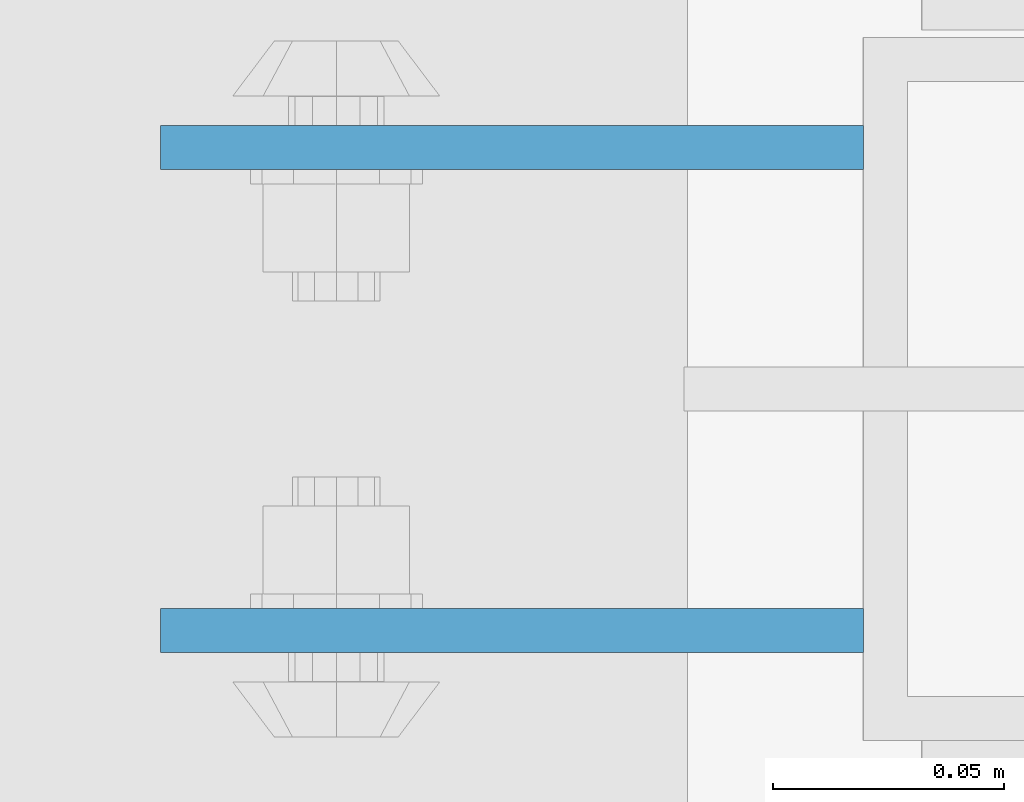
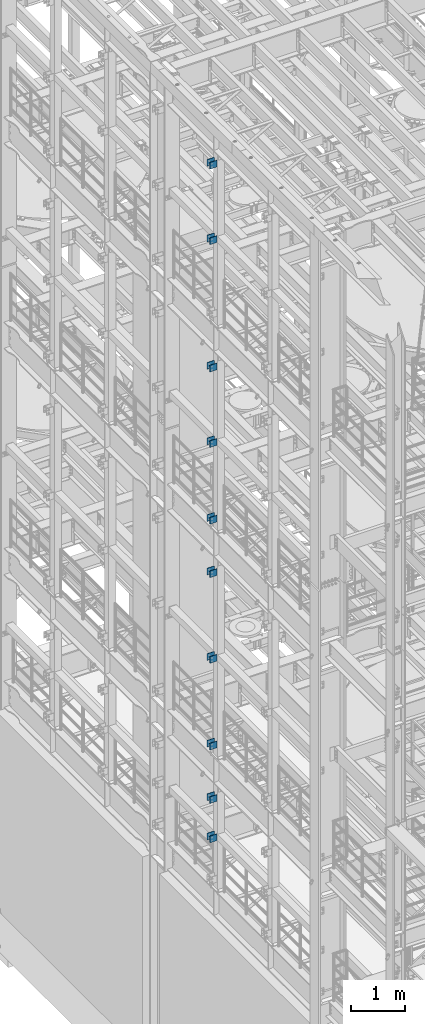
# One storey, part 1232 of 1876: 20 beams, 4 elements without a shape of their own.
"""IFC2X3 building model written with IfcOpenShell, lengths in millimetres."""

from ifc_helpers import new_model, si_unit, frame, origin_with_axes, place, context, subcontext, project, spatial, faceted_brep, material, type_object, element, aggregate, save


model = new_model("IFC2X3")

# Units and contexts
model_context = context("Model", 3, precision=1e-05, world=origin_with_axes())
body_context = subcontext(model_context, "Body", "Model", "MODEL_VIEW")
ifc_project = project(units=[si_unit("LENGTHUNIT", "METRE", prefix="MILLI"), si_unit("AREAUNIT", "SQUARE_METRE"), si_unit("VOLUMEUNIT", "CUBIC_METRE"), si_unit("MASSUNIT", "GRAM", prefix="KILO"), si_unit("TIMEUNIT", "SECOND"), si_unit("PLANEANGLEUNIT", "RADIAN"), si_unit("SOLIDANGLEUNIT", "STERADIAN"), si_unit("THERMODYNAMICTEMPERATUREUNIT", "DEGREE_CELSIUS"), si_unit("LUMINOUSINTENSITYUNIT", "LUMEN")], contexts=[model_context])

# Site, building, storey
site_placement = place(None, origin_with_axes())
site = spatial("IfcSite", under=ifc_project, at=site_placement, CompositionType="ELEMENT")
building_placement = place(site_placement, origin_with_axes())
building = spatial("IfcBuilding", under=site, at=building_placement, Name="Undefined", CompositionType="ELEMENT")
storey_placement = place(building_placement, origin_with_axes())
storey = spatial("IfcBuildingStorey", under=building, at=storey_placement, Name="Undefined", CompositionType="ELEMENT", Elevation=0.0)

# Assembly, beams
assembly_1_placement = place(storey_placement, origin_with_axes())
assembly_1 = element("IfcElementAssembly", 1, at=assembly_1_placement, inside=storey, Name="BEAM", AssemblyPlace="NOTDEFINED", PredefinedType="RIGID_FRAME")
ifc_material = material(Name="STEEL/A36")
beam_type = type_object("IfcBeamType", PredefinedType="NOTDEFINED")
beam_1_placement = place(assembly_1_placement, frame((-76.2000002548895, -455.6125, 21678.9), z_axis=(0.0, 0.0, -1.0), x_axis=(-1.0, 0.0, 0.0)))
beam_1 = element("IfcBeam", 2, at=beam_1_placement, type_object=beam_type, material=ifc_material, Name="PLATE", context=body_context, shape_type="Brep", body=[
    faceted_brep([(0.0, 4.76249999999982, -76.1999999999998), (3.63797880709171e-12, 4.76249999999982, 76.1999969482422), (152.399993896484, 4.76250000000073, 76.1999969482422), (152.4, 4.76249999999982, -76.1999999999998), (3.63797880709171e-12, -4.76249999999982, 76.1999969482422), (152.399993896484, -4.76250000000073, 76.1999969482422), (0.0, -4.76249999999982, -76.1999999999998), (152.4, -4.76249999999982, -76.1999999999998)], [[[0, 1, 2, 3]], [[4, 5, 2, 1]], [[4, 6, 7, 5]], [[6, 0, 3, 7]], [[5, 7, 3, 2]], [[6, 4, 1, 0]]]),
])
beam_2_placement = place(assembly_1_placement, frame((-76.2000002548895, -560.3875, 21678.9), z_axis=(0.0, 0.0, -1.0), x_axis=(-1.0, 0.0, 0.0)))
beam_2 = element("IfcBeam", 3, at=beam_2_placement, type_object=beam_type, material=ifc_material, Name="PLATE", context=body_context, shape_type="Brep", body=[
    faceted_brep([(0.0, 4.76249999999982, -76.1999999999998), (3.63797880709171e-12, 4.76249999999982, 76.1999969482422), (152.399993896484, 4.76250000000073, 76.1999969482422), (152.4, 4.76249999999982, -76.1999999999998), (3.63797880709171e-12, -4.76249999999982, 76.1999969482422), (152.399993896484, -4.76250000000073, 76.1999969482422), (0.0, -4.76249999999982, -76.1999999999998), (152.4, -4.76249999999982, -76.1999999999998)], [[[0, 1, 2, 3]], [[4, 5, 2, 1]], [[4, 6, 7, 5]], [[6, 0, 3, 7]], [[5, 7, 3, 2]], [[6, 4, 1, 0]]]),
])
beam_3_placement = place(assembly_1_placement, frame((-76.2000002548895, -455.6125, 19958.05), z_axis=(0.0, 0.0, -1.0), x_axis=(-1.0, 0.0, 0.0)))
beam_3 = element("IfcBeam", 4, at=beam_3_placement, type_object=beam_type, material=ifc_material, Name="PLATE", context=body_context, shape_type="Brep", body=[
    faceted_brep([(0.0, 4.76249999999982, -76.1999999999998), (3.63797880709171e-12, 4.76249999999982, 76.1999969482422), (152.399993896484, 4.76250000000073, 76.1999969482422), (152.4, 4.76249999999982, -76.1999999999998), (3.63797880709171e-12, -4.76249999999982, 76.1999969482422), (152.399993896484, -4.76250000000073, 76.1999969482422), (0.0, -4.76249999999982, -76.1999999999998), (152.4, -4.76249999999982, -76.1999999999998)], [[[0, 1, 2, 3]], [[4, 5, 2, 1]], [[4, 6, 7, 5]], [[6, 0, 3, 7]], [[5, 7, 3, 2]], [[6, 4, 1, 0]]]),
])
beam_4_placement = place(assembly_1_placement, frame((-76.2000002548895, -560.3875, 19958.05), z_axis=(0.0, 0.0, -1.0), x_axis=(-1.0, 0.0, 0.0)))
beam_4 = element("IfcBeam", 5, at=beam_4_placement, type_object=beam_type, material=ifc_material, Name="PLATE", context=body_context, shape_type="Brep", body=[
    faceted_brep([(0.0, 4.76249999999982, -76.1999999999998), (3.63797880709171e-12, 4.76249999999982, 76.1999969482422), (152.399993896484, 4.76250000000073, 76.1999969482422), (152.4, 4.76249999999982, -76.1999999999998), (3.63797880709171e-12, -4.76249999999982, 76.1999969482422), (152.399993896484, -4.76250000000073, 76.1999969482422), (0.0, -4.76249999999982, -76.1999999999998), (152.4, -4.76249999999982, -76.1999999999998)], [[[0, 1, 2, 3]], [[4, 5, 2, 1]], [[4, 6, 7, 5]], [[6, 0, 3, 7]], [[5, 7, 3, 2]], [[6, 4, 1, 0]]]),
])
aggregate(assembly_1, [beam_1, beam_2, beam_3, beam_4])

assembly_2_placement = place(storey_placement, origin_with_axes())
assembly_2 = element("IfcElementAssembly", 6, at=assembly_2_placement, inside=storey, Name="BEAM", AssemblyPlace="NOTDEFINED", PredefinedType="RIGID_FRAME")
beam_5_placement = place(assembly_2_placement, frame((-76.1999999999999, -455.6125, 13589.0), z_axis=(0.0, 0.0, -1.0), x_axis=(-1.0, 0.0, 0.0)))
beam_5 = element("IfcBeam", 7, at=beam_5_placement, type_object=beam_type, material=ifc_material, Name="PLATE", context=body_context, shape_type="Brep", body=[
    faceted_brep([(0.0, 4.76249999999982, -76.1999999999998), (3.63797880709171e-12, 4.76249999999982, 76.1999969482422), (152.399993896484, 4.76250000000073, 76.1999969482422), (152.4, 4.76249999999982, -76.1999999999998), (3.63797880709171e-12, -4.76249999999982, 76.1999969482422), (152.399993896484, -4.76250000000073, 76.1999969482422), (0.0, -4.76249999999982, -76.1999999999998), (152.4, -4.76249999999982, -76.1999999999998)], [[[0, 1, 2, 3]], [[4, 5, 2, 1]], [[4, 6, 7, 5]], [[6, 0, 3, 7]], [[5, 7, 3, 2]], [[6, 4, 1, 0]]]),
])
beam_6_placement = place(assembly_2_placement, frame((-76.1999999999999, -560.3875, 13589.0), z_axis=(0.0, 0.0, -1.0), x_axis=(-1.0, 0.0, 0.0)))
beam_6 = element("IfcBeam", 8, at=beam_6_placement, type_object=beam_type, material=ifc_material, Name="PLATE", context=body_context, shape_type="Brep", body=[
    faceted_brep([(0.0, 4.76249999999982, -76.1999999999998), (3.63797880709171e-12, 4.76249999999982, 76.1999969482422), (152.399993896484, 4.76250000000073, 76.1999969482422), (152.4, 4.76249999999982, -76.1999999999998), (3.63797880709171e-12, -4.76249999999982, 76.1999969482422), (152.399993896484, -4.76250000000073, 76.1999969482422), (0.0, -4.76249999999982, -76.1999999999998), (152.4, -4.76249999999982, -76.1999999999998)], [[[0, 1, 2, 3]], [[4, 5, 2, 1]], [[4, 6, 7, 5]], [[6, 0, 3, 7]], [[5, 7, 3, 2]], [[6, 4, 1, 0]]]),
])
beam_7_placement = place(assembly_2_placement, frame((-76.2, -455.6125, 17056.1), z_axis=(0.0, 0.0, -1.0), x_axis=(-1.0, 0.0, 0.0)))
beam_7 = element("IfcBeam", 9, at=beam_7_placement, type_object=beam_type, material=ifc_material, Name="PLATE", context=body_context, shape_type="Brep", body=[
    faceted_brep([(0.0, 4.76249999999982, -76.1999999999998), (3.63797880709171e-12, 4.76249999999982, 76.1999969482422), (152.399993896484, 4.76250000000073, 76.1999969482422), (152.4, 4.76249999999982, -76.1999999999998), (3.63797880709171e-12, -4.76249999999982, 76.1999969482422), (152.399993896484, -4.76250000000073, 76.1999969482422), (0.0, -4.76249999999982, -76.1999999999998), (152.4, -4.76249999999982, -76.1999999999998)], [[[0, 1, 2, 3]], [[4, 5, 2, 1]], [[4, 6, 7, 5]], [[6, 0, 3, 7]], [[5, 7, 3, 2]], [[6, 4, 1, 0]]]),
])
beam_8_placement = place(assembly_2_placement, frame((-76.2, -560.3875, 17056.1), z_axis=(0.0, 0.0, -1.0), x_axis=(-1.0, 0.0, 0.0)))
beam_8 = element("IfcBeam", 10, at=beam_8_placement, type_object=beam_type, material=ifc_material, Name="PLATE", context=body_context, shape_type="Brep", body=[
    faceted_brep([(0.0, 4.76249999999982, -76.1999999999998), (3.63797880709171e-12, 4.76249999999982, 76.1999969482422), (152.399993896484, 4.76250000000073, 76.1999969482422), (152.4, 4.76249999999982, -76.1999999999998), (3.63797880709171e-12, -4.76249999999982, 76.1999969482422), (152.399993896484, -4.76250000000073, 76.1999969482422), (0.0, -4.76249999999982, -76.1999999999998), (152.4, -4.76249999999982, -76.1999999999998)], [[[0, 1, 2, 3]], [[4, 5, 2, 1]], [[4, 6, 7, 5]], [[6, 0, 3, 7]], [[5, 7, 3, 2]], [[6, 4, 1, 0]]]),
])
beam_9_placement = place(assembly_2_placement, frame((-76.2, -455.6125, 15335.25), z_axis=(0.0, 0.0, -1.0), x_axis=(-1.0, 0.0, 0.0)))
beam_9 = element("IfcBeam", 11, at=beam_9_placement, type_object=beam_type, material=ifc_material, Name="PLATE", context=body_context, shape_type="Brep", body=[
    faceted_brep([(0.0, 4.76249999999982, -76.1999999999998), (3.63797880709171e-12, 4.76249999999982, 76.1999969482422), (152.399993896484, 4.76250000000073, 76.1999969482422), (152.4, 4.76249999999982, -76.1999999999998), (3.63797880709171e-12, -4.76249999999982, 76.1999969482422), (152.399993896484, -4.76250000000073, 76.1999969482422), (0.0, -4.76249999999982, -76.1999999999998), (152.4, -4.76249999999982, -76.1999999999998)], [[[0, 1, 2, 3]], [[4, 5, 2, 1]], [[4, 6, 7, 5]], [[6, 0, 3, 7]], [[5, 7, 3, 2]], [[6, 4, 1, 0]]]),
])
beam_10_placement = place(assembly_2_placement, frame((-76.2, -560.3875, 15335.25), z_axis=(0.0, 0.0, -1.0), x_axis=(-1.0, 0.0, 0.0)))
beam_10 = element("IfcBeam", 12, at=beam_10_placement, type_object=beam_type, material=ifc_material, Name="PLATE", context=body_context, shape_type="Brep", body=[
    faceted_brep([(0.0, 4.76249999999982, -76.1999999999998), (3.63797880709171e-12, 4.76249999999982, 76.1999969482422), (152.399993896484, 4.76250000000073, 76.1999969482422), (152.4, 4.76249999999982, -76.1999999999998), (3.63797880709171e-12, -4.76249999999982, 76.1999969482422), (152.399993896484, -4.76250000000073, 76.1999969482422), (0.0, -4.76249999999982, -76.1999999999998), (152.4, -4.76249999999982, -76.1999999999998)], [[[0, 1, 2, 3]], [[4, 5, 2, 1]], [[4, 6, 7, 5]], [[6, 0, 3, 7]], [[5, 7, 3, 2]], [[6, 4, 1, 0]]]),
])
aggregate(assembly_2, [beam_5, beam_6, beam_7, beam_8, beam_9, beam_10])

assembly_3_placement = place(storey_placement, origin_with_axes())
assembly_3 = element("IfcElementAssembly", 13, at=assembly_3_placement, inside=storey, Name="BEAM", AssemblyPlace="NOTDEFINED", PredefinedType="RIGID_FRAME")
beam_11_placement = place(assembly_3_placement, frame((-76.1999999999999, -455.6125, 12369.8), z_axis=(0.0, 0.0, -1.0), x_axis=(-1.0, 0.0, 0.0)))
beam_11 = element("IfcBeam", 14, at=beam_11_placement, type_object=beam_type, material=ifc_material, Name="PLATE", context=body_context, shape_type="Brep", body=[
    faceted_brep([(0.0, 4.76249999999982, -76.1999999999998), (3.63797880709171e-12, 4.76249999999982, 76.1999969482422), (152.399993896484, 4.76250000000073, 76.1999969482422), (152.4, 4.76249999999982, -76.1999999999998), (3.63797880709171e-12, -4.76249999999982, 76.1999969482422), (152.399993896484, -4.76250000000073, 76.1999969482422), (0.0, -4.76249999999982, -76.1999999999998), (152.4, -4.76249999999982, -76.1999999999998)], [[[0, 1, 2, 3]], [[4, 5, 2, 1]], [[4, 6, 7, 5]], [[6, 0, 3, 7]], [[5, 7, 3, 2]], [[6, 4, 1, 0]]]),
])
beam_12_placement = place(assembly_3_placement, frame((-76.1999999999999, -560.3875, 12369.8), z_axis=(0.0, 0.0, -1.0), x_axis=(-1.0, 0.0, 0.0)))
beam_12 = element("IfcBeam", 15, at=beam_12_placement, type_object=beam_type, material=ifc_material, Name="PLATE", context=body_context, shape_type="Brep", body=[
    faceted_brep([(0.0, 4.76249999999982, -76.1999999999998), (3.63797880709171e-12, 4.76249999999982, 76.1999969482422), (152.399993896484, 4.76250000000073, 76.1999969482422), (152.4, 4.76249999999982, -76.1999999999998), (3.63797880709171e-12, -4.76249999999982, 76.1999969482422), (152.399993896484, -4.76250000000073, 76.1999969482422), (0.0, -4.76249999999982, -76.1999999999998), (152.4, -4.76249999999982, -76.1999999999998)], [[[0, 1, 2, 3]], [[4, 5, 2, 1]], [[4, 6, 7, 5]], [[6, 0, 3, 7]], [[5, 7, 3, 2]], [[6, 4, 1, 0]]]),
])
beam_13_placement = place(assembly_3_placement, frame((-76.2, -455.6125, 8445.5), z_axis=(0.0, 0.0, -1.0), x_axis=(-1.0, 0.0, 0.0)))
beam_13 = element("IfcBeam", 16, at=beam_13_placement, type_object=beam_type, material=ifc_material, Name="PLATE", context=body_context, shape_type="Brep", body=[
    faceted_brep([(0.0, 4.76249999999982, -76.1999999999998), (3.63797880709171e-12, 4.76249999999982, 76.1999969482422), (152.399993896484, 4.76250000000073, 76.1999969482422), (152.4, 4.76249999999982, -76.1999999999998), (3.63797880709171e-12, -4.76249999999982, 76.1999969482422), (152.399993896484, -4.76250000000073, 76.1999969482422), (0.0, -4.76249999999982, -76.1999999999998), (152.4, -4.76249999999982, -76.1999999999998)], [[[0, 1, 2, 3]], [[4, 5, 2, 1]], [[4, 6, 7, 5]], [[6, 0, 3, 7]], [[5, 7, 3, 2]], [[6, 4, 1, 0]]]),
])
beam_14_placement = place(assembly_3_placement, frame((-76.2, -560.3875, 8445.5), z_axis=(0.0, 0.0, -1.0), x_axis=(-1.0, 0.0, 0.0)))
beam_14 = element("IfcBeam", 17, at=beam_14_placement, type_object=beam_type, material=ifc_material, Name="PLATE", context=body_context, shape_type="Brep", body=[
    faceted_brep([(0.0, 4.76249999999982, -76.1999999999998), (3.63797880709171e-12, 4.76249999999982, 76.1999969482422), (152.399993896484, 4.76250000000073, 76.1999969482422), (152.4, 4.76249999999982, -76.1999999999998), (3.63797880709171e-12, -4.76249999999982, 76.1999969482422), (152.399993896484, -4.76250000000073, 76.1999969482422), (0.0, -4.76249999999982, -76.1999999999998), (152.4, -4.76249999999982, -76.1999999999998)], [[[0, 1, 2, 3]], [[4, 5, 2, 1]], [[4, 6, 7, 5]], [[6, 0, 3, 7]], [[5, 7, 3, 2]], [[6, 4, 1, 0]]]),
])
beam_15_placement = place(assembly_3_placement, frame((-76.2, -455.6125, 10420.35), z_axis=(0.0, 0.0, -1.0), x_axis=(-1.0, 0.0, 0.0)))
beam_15 = element("IfcBeam", 18, at=beam_15_placement, type_object=beam_type, material=ifc_material, Name="PLATE", context=body_context, shape_type="Brep", body=[
    faceted_brep([(0.0, 4.76249999999982, -76.1999999999998), (3.63797880709171e-12, 4.76249999999982, 76.1999969482422), (152.399993896484, 4.76250000000073, 76.1999969482422), (152.4, 4.76249999999982, -76.1999999999998), (3.63797880709171e-12, -4.76249999999982, 76.1999969482422), (152.399993896484, -4.76250000000073, 76.1999969482422), (0.0, -4.76249999999982, -76.1999999999998), (152.4, -4.76249999999982, -76.1999999999998)], [[[0, 1, 2, 3]], [[4, 5, 2, 1]], [[4, 6, 7, 5]], [[6, 0, 3, 7]], [[5, 7, 3, 2]], [[6, 4, 1, 0]]]),
])
beam_16_placement = place(assembly_3_placement, frame((-76.2, -560.3875, 10420.35), z_axis=(0.0, 0.0, -1.0), x_axis=(-1.0, 0.0, 0.0)))
beam_16 = element("IfcBeam", 19, at=beam_16_placement, type_object=beam_type, material=ifc_material, Name="PLATE", context=body_context, shape_type="Brep", body=[
    faceted_brep([(0.0, 4.76249999999982, -76.1999999999998), (3.63797880709171e-12, 4.76249999999982, 76.1999969482422), (152.399993896484, 4.76250000000073, 76.1999969482422), (152.4, 4.76249999999982, -76.1999999999998), (3.63797880709171e-12, -4.76249999999982, 76.1999969482422), (152.399993896484, -4.76250000000073, 76.1999969482422), (0.0, -4.76249999999982, -76.1999999999998), (152.4, -4.76249999999982, -76.1999999999998)], [[[0, 1, 2, 3]], [[4, 5, 2, 1]], [[4, 6, 7, 5]], [[6, 0, 3, 7]], [[5, 7, 3, 2]], [[6, 4, 1, 0]]]),
])
aggregate(assembly_3, [beam_11, beam_12, beam_13, beam_14, beam_15, beam_16])

assembly_4_placement = place(storey_placement, origin_with_axes())
assembly_4 = element("IfcElementAssembly", 20, at=assembly_4_placement, inside=storey, Name="BEAM", AssemblyPlace="NOTDEFINED", PredefinedType="RIGID_FRAME")
beam_17_placement = place(assembly_4_placement, frame((-76.2, -455.612499999999, 6330.95), z_axis=(0.0, 0.0, -1.0), x_axis=(-1.0, 0.0, 0.0)))
beam_17 = element("IfcBeam", 21, at=beam_17_placement, type_object=beam_type, material=ifc_material, Name="PLATE", context=body_context, shape_type="Brep", body=[
    faceted_brep([(0.0, 4.76249999999982, -76.1999999999998), (3.63797880709171e-12, 4.76249999999982, 76.1999969482422), (152.399993896484, 4.76250000000073, 76.1999969482422), (152.4, 4.76249999999982, -76.1999999999998), (3.63797880709171e-12, -4.76249999999982, 76.1999969482422), (152.399993896484, -4.76250000000073, 76.1999969482422), (0.0, -4.76249999999982, -76.1999999999998), (152.4, -4.76249999999982, -76.1999999999998)], [[[0, 1, 2, 3]], [[4, 5, 2, 1]], [[4, 6, 7, 5]], [[6, 0, 3, 7]], [[5, 7, 3, 2]], [[6, 4, 1, 0]]]),
])
beam_18_placement = place(assembly_4_placement, frame((-76.2, -560.387500000001, 6330.95), z_axis=(0.0, 0.0, -1.0), x_axis=(-1.0, 0.0, 0.0)))
beam_18 = element("IfcBeam", 22, at=beam_18_placement, type_object=beam_type, material=ifc_material, Name="PLATE", context=body_context, shape_type="Brep", body=[
    faceted_brep([(0.0, 4.76249999999982, -76.1999999999998), (3.63797880709171e-12, 4.76249999999982, 76.1999969482422), (152.399993896484, 4.76250000000073, 76.1999969482422), (152.4, 4.76249999999982, -76.1999999999998), (3.63797880709171e-12, -4.76249999999982, 76.1999969482422), (152.399993896484, -4.76250000000073, 76.1999969482422), (0.0, -4.76249999999982, -76.1999999999998), (152.4, -4.76249999999982, -76.1999999999998)], [[[0, 1, 2, 3]], [[4, 5, 2, 1]], [[4, 6, 7, 5]], [[6, 0, 3, 7]], [[5, 7, 3, 2]], [[6, 4, 1, 0]]]),
])
beam_19_placement = place(assembly_4_placement, frame((-76.2, -455.612499999999, 7226.3), z_axis=(0.0, 0.0, -1.0), x_axis=(-1.0, 0.0, 0.0)))
beam_19 = element("IfcBeam", 23, at=beam_19_placement, type_object=beam_type, material=ifc_material, Name="PLATE", context=body_context, shape_type="Brep", body=[
    faceted_brep([(0.0, 4.76249999999982, -76.1999999999998), (3.63797880709171e-12, 4.76249999999982, 76.1999969482422), (152.399993896484, 4.76250000000073, 76.1999969482422), (152.4, 4.76249999999982, -76.1999999999998), (3.63797880709171e-12, -4.76249999999982, 76.1999969482422), (152.399993896484, -4.76250000000073, 76.1999969482422), (0.0, -4.76249999999982, -76.1999999999998), (152.4, -4.76249999999982, -76.1999999999998)], [[[0, 1, 2, 3]], [[4, 5, 2, 1]], [[4, 6, 7, 5]], [[6, 0, 3, 7]], [[5, 7, 3, 2]], [[6, 4, 1, 0]]]),
])
beam_20_placement = place(assembly_4_placement, frame((-76.2, -560.387500000001, 7226.3), z_axis=(0.0, 0.0, -1.0), x_axis=(-1.0, 0.0, 0.0)))
beam_20 = element("IfcBeam", 24, at=beam_20_placement, type_object=beam_type, material=ifc_material, Name="PLATE", context=body_context, shape_type="Brep", body=[
    faceted_brep([(0.0, 4.76249999999982, -76.1999999999998), (3.63797880709171e-12, 4.76249999999982, 76.1999969482422), (152.399993896484, 4.76250000000073, 76.1999969482422), (152.4, 4.76249999999982, -76.1999999999998), (3.63797880709171e-12, -4.76249999999982, 76.1999969482422), (152.399993896484, -4.76250000000073, 76.1999969482422), (0.0, -4.76249999999982, -76.1999999999998), (152.4, -4.76249999999982, -76.1999999999998)], [[[0, 1, 2, 3]], [[4, 5, 2, 1]], [[4, 6, 7, 5]], [[6, 0, 3, 7]], [[5, 7, 3, 2]], [[6, 4, 1, 0]]]),
])
aggregate(assembly_4, [beam_17, beam_18, beam_19, beam_20])

save(model, "model.ifc")
